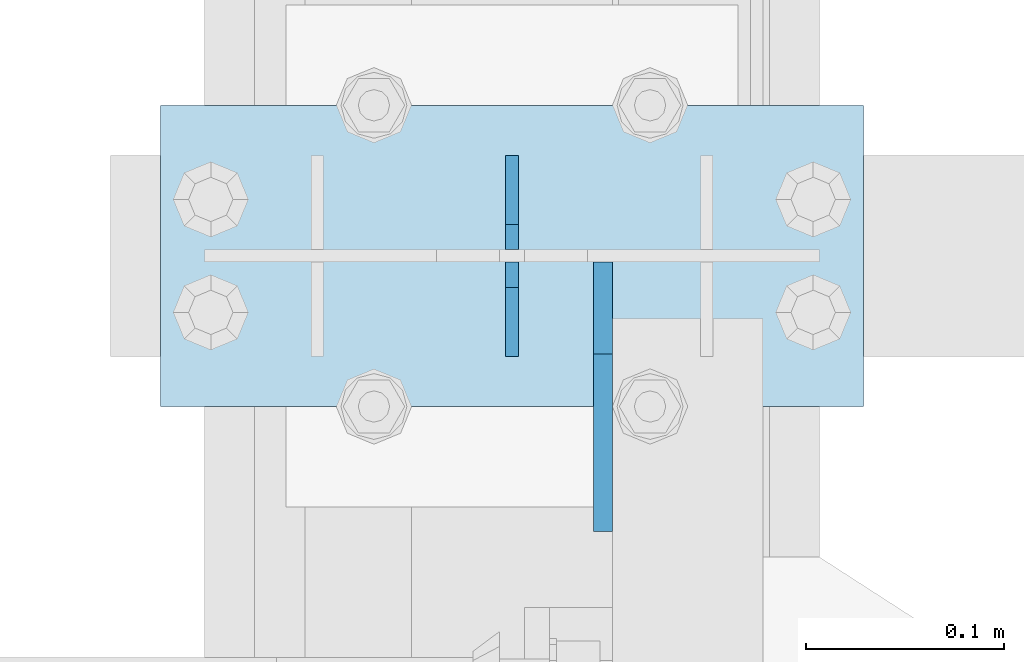
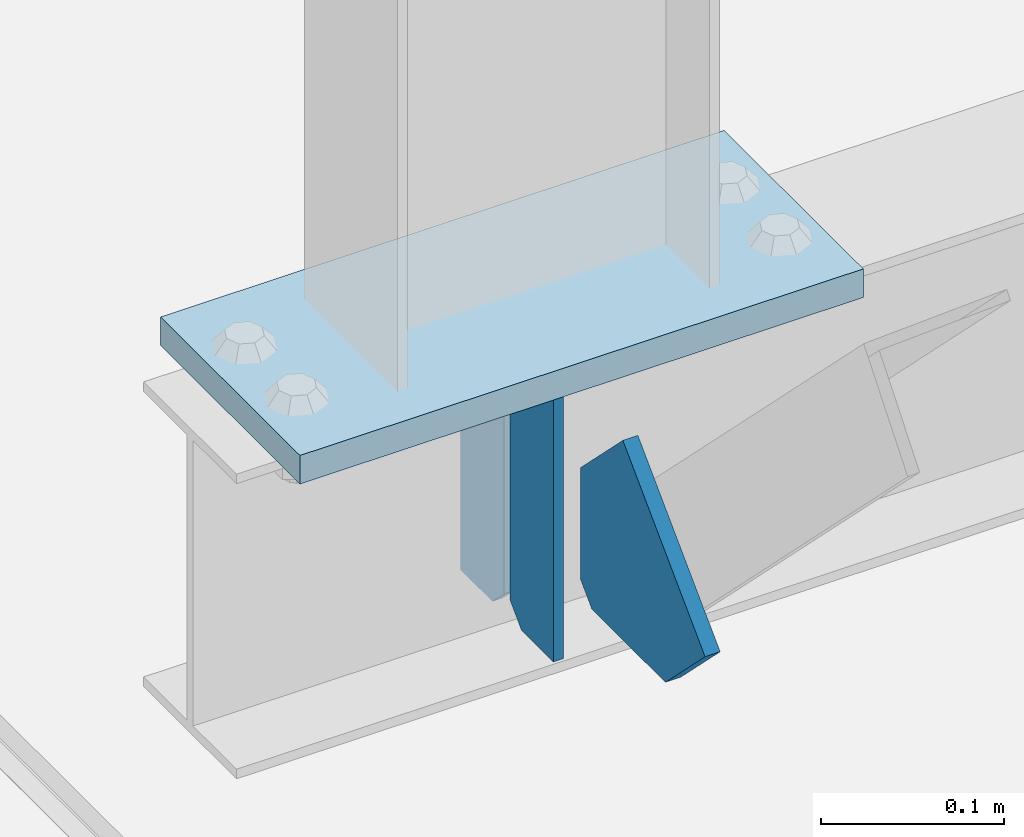
# One storey, part 3021 of 3843: 4 plates, 2 elements without a shape of their own.
"""IFC2X3 building model written with IfcOpenShell, lengths in millimetres."""

from ifc_helpers import new_model, si_unit, frame, origin_with_axes, place, context, subcontext, project, spatial, faceted_brep, material, type_object, element, aggregate, save


model = new_model("IFC2X3")

# Units and contexts
model_context = context("Model", 3, precision=1e-05, world=origin_with_axes())
body_context = subcontext(model_context, "Body", "Model", "MODEL_VIEW")
ifc_project = project(units=[si_unit("LENGTHUNIT", "METRE", prefix="MILLI"), si_unit("AREAUNIT", "SQUARE_METRE"), si_unit("VOLUMEUNIT", "CUBIC_METRE"), si_unit("MASSUNIT", "GRAM", prefix="KILO"), si_unit("TIMEUNIT", "SECOND"), si_unit("PLANEANGLEUNIT", "RADIAN"), si_unit("SOLIDANGLEUNIT", "STERADIAN"), si_unit("THERMODYNAMICTEMPERATUREUNIT", "DEGREE_CELSIUS"), si_unit("LUMINOUSINTENSITYUNIT", "LUMEN")], contexts=[model_context])

# Site, building, storey
site_placement = place(None, origin_with_axes())
site = spatial("IfcSite", under=ifc_project, at=site_placement, CompositionType="ELEMENT")
building_placement = place(site_placement, origin_with_axes())
building = spatial("IfcBuilding", under=site, at=building_placement, Name="Undefined", CompositionType="ELEMENT")
storey_placement = place(building_placement, origin_with_axes())
storey = spatial("IfcBuildingStorey", under=building, at=storey_placement, Name="Undefined", CompositionType="ELEMENT", Elevation=0.0)

# Assembly, plates
assembly_1_placement = place(storey_placement, origin_with_axes())
assembly_1 = element("IfcElementAssembly", 1, at=assembly_1_placement, inside=storey, Name="BEAM", AssemblyPlace="NOTDEFINED", PredefinedType="RIGID_FRAME")
ifc_material = material(Name="STEEL/A572-50")
plate_type_1 = type_object("IfcPlateType", PredefinedType="NOTDEFINED")
plate_1_placement = place(assembly_1_placement, frame((36576.0000030517, 27038.3, 41495.6625), z_axis=(0.0, 0.0, -1.0), x_axis=(0.0, -1.0, 0.0)))
plate_1 = element("IfcPlate", 2, at=plate_1_placement, type_object=plate_type_1, material=ifc_material, Name="PLATE", context=body_context, shape_type="Brep", body=[
    faceted_brep([(0.0, -3.17499999999927, 0.0), (0.0, -3.17500000000291, 187.324999999997), (0.0, 3.17500000000291, 187.324999999997), (0.0, 3.17499999999927, 0.0), (34.9250001907349, -3.17500000000291, 187.324999999997), (34.9250001907349, 3.17500000000291, 187.324999999997), (47.625, -3.17500000000291, 174.625000190732), (47.625, 3.17500000000291, 174.625000190732), (47.625, -3.17499999999927, 12.6999998092651), (47.625, 3.17499999999927, 12.6999998092651), (34.9250001907349, -3.17499999999927, 0.0), (34.9250001907349, 3.17499999999927, 0.0)], [[[0, 1, 2, 3]], [[1, 4, 5, 2]], [[4, 6, 7, 5]], [[6, 8, 9, 7]], [[8, 10, 11, 9]], [[10, 0, 3, 11]], [[5, 7, 9, 11, 3, 2]], [[10, 8, 6, 4, 1, 0]]]),
])
plate_2_placement = place(assembly_1_placement, frame((36576.0000030517, 26936.7, 41495.6625), z_axis=(0.0, 0.0, -1.0), x_axis=(0.0, 1.0, 0.0)))
plate_2 = element("IfcPlate", 3, at=plate_2_placement, type_object=plate_type_1, material=ifc_material, Name="PLATE", context=body_context, shape_type="Brep", body=[
    faceted_brep([(0.0, -3.17499999999927, 0.0), (0.0, -3.17500000000291, 187.324999999997), (0.0, 3.17500000000291, 187.324999999997), (0.0, 3.17499999999927, 0.0), (34.9250001907349, -3.17500000000291, 187.324999999997), (34.9250001907349, 3.17500000000291, 187.324999999997), (47.625, -3.17500000000291, 174.625000190732), (47.625, 3.17500000000291, 174.625000190732), (47.625, -3.17499999999927, 12.6999998092651), (47.625, 3.17499999999927, 12.6999998092651), (34.9250001907349, -3.17499999999927, 0.0), (34.9250001907349, 3.17499999999927, 0.0)], [[[0, 1, 2, 3]], [[1, 4, 5, 2]], [[4, 6, 7, 5]], [[6, 8, 9, 7]], [[8, 10, 11, 9]], [[10, 0, 3, 11]], [[5, 7, 9, 11, 3, 2]], [[10, 8, 6, 4, 1, 0]]]),
])

# Assembly, plate
assembly_2_placement = place(storey_placement, origin_with_axes())
assembly_2 = element("IfcElementAssembly", 4, at=assembly_2_placement, inside=storey, Name="POST", AssemblyPlace="NOTDEFINED", PredefinedType="RIGID_FRAME")
plate_type_2 = type_object("IfcPlateType", PredefinedType="NOTDEFINED")
plate_3_placement = place(assembly_2_placement, frame((36753.8000030518, 26911.3, 41513.125), z_axis=(-1.0, 0.0, 0.0), x_axis=(0.0, 1.0, 0.0)))
plate_3 = element("IfcPlate", 5, at=plate_3_placement, type_object=plate_type_2, material=ifc_material, Name="PLATE", context=body_context, shape_type="Brep", body=[
    faceted_brep([(0.0, -9.52500000000146, 0.0), (0.0, -9.52500000000146, 355.599999999999), (0.0, 9.52500000000146, 355.599999999999), (0.0, 9.52500000000146, 0.0), (152.399999999994, -9.52500000000146, 355.599999999999), (152.399999999994, 9.52500000000146, 355.599999999999), (152.400000000001, -9.52500000000146, 0.0), (152.400000000001, 9.52500000000146, 0.0)], [[[0, 1, 2, 3]], [[1, 4, 5, 2]], [[4, 6, 7, 5]], [[6, 0, 3, 7]], [[5, 7, 3, 2]], [[6, 4, 1, 0]]]),
])
aggregate(assembly_2, [plate_3])

# Plate
plate_type_3 = type_object("IfcPlateType", PredefinedType="NOTDEFINED")
plate_4_placement = place(assembly_1_placement, frame((36622.0375, 26984.325, 41306.75), z_axis=(0.0, -1.0, 0.0), x_axis=(0.0, 0.0, 1.0)))
plate_4 = element("IfcPlate", 6, at=plate_4_placement, type_object=plate_type_3, material=ifc_material, Name="PLATE", context=body_context, shape_type="Brep", body=[
    faceted_brep([(0.0, -4.76250000000073, 12.6999998092651), (4.450703272596e-08, -4.76249999999709, 93.0710244828806), (4.450703272596e-08, 4.76249999999709, 93.0710244828806), (0.0, 4.76250000000073, 12.6999998092651), (43.3137807601452, -4.76249999999709, 136.384805065652), (43.3137807601452, 4.76249999999709, 136.384805065652), (133.209805202001, -4.76249999999709, 46.4887805392646), (133.209805202001, 4.76249999999709, 46.4887805392646), (86.7210245267561, -4.76249999999709, 0.0), (86.7210245267561, 4.76249999999709, 0.0), (12.6999998092651, -4.76250000000073, 0.0), (12.6999998092651, 4.76250000000073, 0.0)], [[[0, 1, 2, 3]], [[1, 4, 5, 2]], [[4, 6, 7, 5]], [[6, 8, 9, 7]], [[8, 10, 11, 9]], [[10, 0, 3, 11]], [[5, 7, 9, 11, 3, 2]], [[10, 8, 6, 4, 1, 0]]]),
])

aggregate(assembly_1, [plate_1, plate_2, plate_4])

save(model, "model.ifc")
